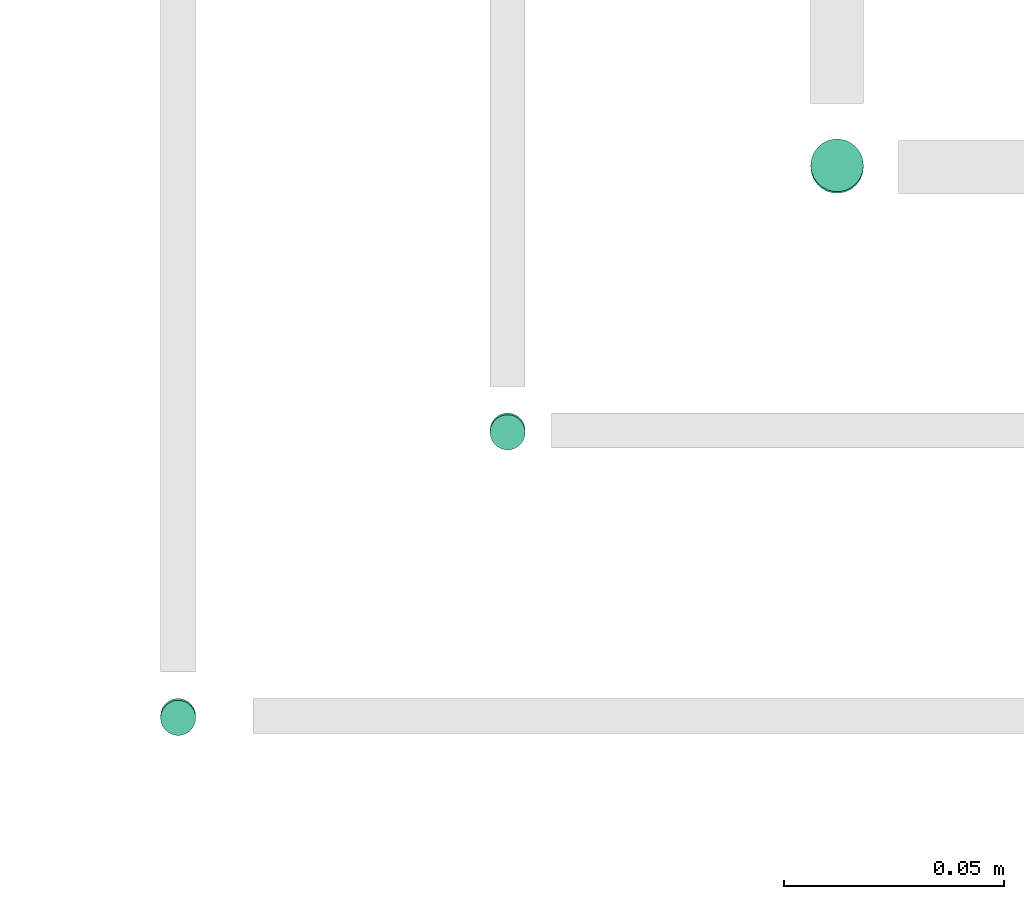
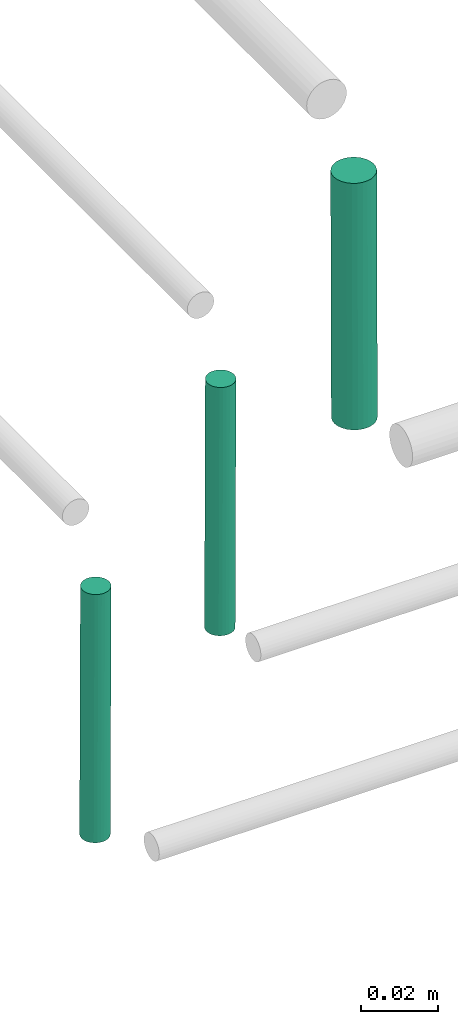
# One storey, part 288 of 331: 3 flow segments.
"""IFC2X3 building model written with IfcOpenShell, lengths in millimetres."""

from ifc_helpers import new_model, entity, si_unit, converted_unit, derived_unit, direction, frame, origin, origin_2d_with_axis, place, context, subcontext, project, spatial, circle, extrude, type_object, element, save


model = new_model("IFC2X3")

# Units and contexts
model_context = context("Model", 3, precision=0.01, world=origin(), true_north=direction((6.12303176911189e-17, 1.0)))
body_context = subcontext(model_context, "Body", "Model", "MODEL_VIEW")
ifc_project = project(units=[si_unit("LENGTHUNIT", "METRE", prefix="MILLI"), si_unit("AREAUNIT", "SQUARE_METRE"), si_unit("VOLUMEUNIT", "CUBIC_METRE"), converted_unit("PLANEANGLEUNIT", "DEGREE", entity("IfcRatioMeasure", 0.0174532925199433), si_unit("PLANEANGLEUNIT", "RADIAN"), dimensions=[0, 0, 0, 0, 0, 0, 0]), si_unit("MASSUNIT", "GRAM", prefix="KILO"), derived_unit("MASSDENSITYUNIT", [(si_unit("MASSUNIT", "GRAM", prefix="KILO"), 1), (si_unit("LENGTHUNIT", "METRE"), -3)]), derived_unit("MOMENTOFINERTIAUNIT", [(si_unit("LENGTHUNIT", "METRE"), 4)]), si_unit("TIMEUNIT", "SECOND"), si_unit("FREQUENCYUNIT", "HERTZ"), si_unit("THERMODYNAMICTEMPERATUREUNIT", "DEGREE_CELSIUS"), derived_unit("THERMALTRANSMITTANCEUNIT", [(si_unit("MASSUNIT", "GRAM", prefix="KILO"), 1), (si_unit("THERMODYNAMICTEMPERATUREUNIT", "KELVIN"), -1), (si_unit("TIMEUNIT", "SECOND"), -3)]), derived_unit("VOLUMETRICFLOWRATEUNIT", [(si_unit("LENGTHUNIT", "METRE"), 3), (si_unit("TIMEUNIT", "SECOND"), -1)]), derived_unit("MASSFLOWRATEUNIT", [(si_unit("MASSUNIT", "GRAM", prefix="KILO"), 1), (si_unit("TIMEUNIT", "SECOND"), -1)]), derived_unit("ROTATIONALFREQUENCYUNIT", [(si_unit("TIMEUNIT", "SECOND"), -1)]), si_unit("ELECTRICCURRENTUNIT", "AMPERE"), si_unit("ELECTRICVOLTAGEUNIT", "VOLT"), si_unit("POWERUNIT", "WATT"), si_unit("FORCEUNIT", "NEWTON", prefix="KILO"), si_unit("ILLUMINANCEUNIT", "LUX"), si_unit("LUMINOUSFLUXUNIT", "LUMEN"), si_unit("LUMINOUSINTENSITYUNIT", "CANDELA"), derived_unit("USERDEFINED", [(si_unit("MASSUNIT", "GRAM", prefix="KILO"), -1), (si_unit("LENGTHUNIT", "METRE"), -2), (si_unit("TIMEUNIT", "SECOND"), 3), (si_unit("LUMINOUSFLUXUNIT", "LUMEN"), 1)]), derived_unit("LINEARVELOCITYUNIT", [(si_unit("LENGTHUNIT", "METRE"), 1), (si_unit("TIMEUNIT", "SECOND"), -1)]), si_unit("PRESSUREUNIT", "PASCAL"), derived_unit("USERDEFINED", [(si_unit("LENGTHUNIT", "METRE"), -2), (si_unit("MASSUNIT", "GRAM", prefix="KILO"), 1), (si_unit("TIMEUNIT", "SECOND"), -2)]), derived_unit("LINEARFORCEUNIT", [(si_unit("MASSUNIT", "GRAM", prefix="KILO"), 1), (si_unit("LENGTHUNIT", "METRE"), 1), (si_unit("TIMEUNIT", "SECOND"), -2), (si_unit("LENGTHUNIT", "METRE"), -1)]), derived_unit("PLANARFORCEUNIT", [(si_unit("MASSUNIT", "GRAM", prefix="KILO"), 1), (si_unit("LENGTHUNIT", "METRE"), 1), (si_unit("TIMEUNIT", "SECOND"), -2), (si_unit("LENGTHUNIT", "METRE"), -2)])], contexts=[model_context])

# Site, building, storey
site_placement = place(None, frame((0.0, -0.00077364408347762, 0.0)))
site = spatial("IfcSite", under=ifc_project, at=site_placement, CompositionType="ELEMENT")
building_placement = place(site_placement, origin())
building = spatial("IfcBuilding", under=site, at=building_placement, CompositionType="ELEMENT")
storey_placement = place(building_placement, origin())
storey = spatial("IfcBuildingStorey", under=building, at=storey_placement, CompositionType="ELEMENT", Elevation=0.0)

# Flow segments
pipe_segment_type = type_object("IfcPipeSegmentType", PredefinedType="NOTDEFINED")
flow_segment_placement = place(building_placement, frame((65227.5100168243, 2867.40460860884, 7263.97296710178)))
element("IfcFlowSegment", 1, at=flow_segment_placement, inside=storey, type_object=pipe_segment_type, context=body_context, shape_type="SweptSolid", body=[
    extrude(circle(Radius=6.0, at=origin_2d_with_axis()), frame((7.59527223591454, 7.59521133747482, 0.0270328982179876), z_axis=(0.0, 0.00450548303621091, 0.999989850259797), x_axis=(1.0, 0.0, 0.0)), (0.0, 0.0, 1.0), 78.0007916877687),
])
for number, where in (
    (2, (65154.5100168243, 2808.99091657001, 7259.97901295961)),
    (3, (65079.5100168243, 2743.99091657001, 7259.97901295961)),
):
    element("IfcFlowSegment", number, at=place(storey_placement, frame(where)), inside=storey, type_object=pipe_segment_type, context=body_context, shape_type="SweptSolid", body=[
        extrude(circle(Radius=4.0, at=origin_2d_with_axis()), frame((5.59527223591499, 5.59521717855424, 79.0226820736776), z_axis=(0.0, 0.00524676009626582, -0.999986235659518), x_axis=(-1.0, 0.0, 0.0)), (0.0, 0.0, 1.0), 79.0027824548393),
    ])

save(model, "model.ifc")
